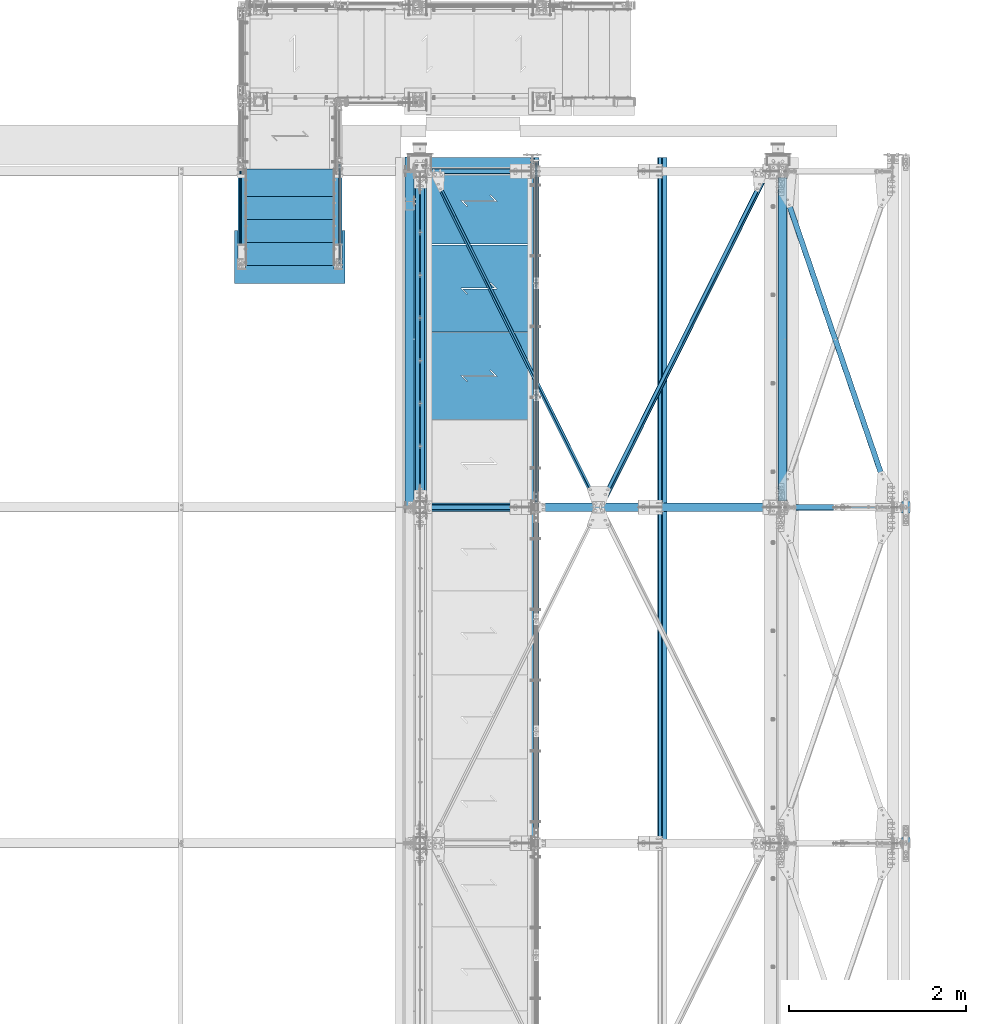
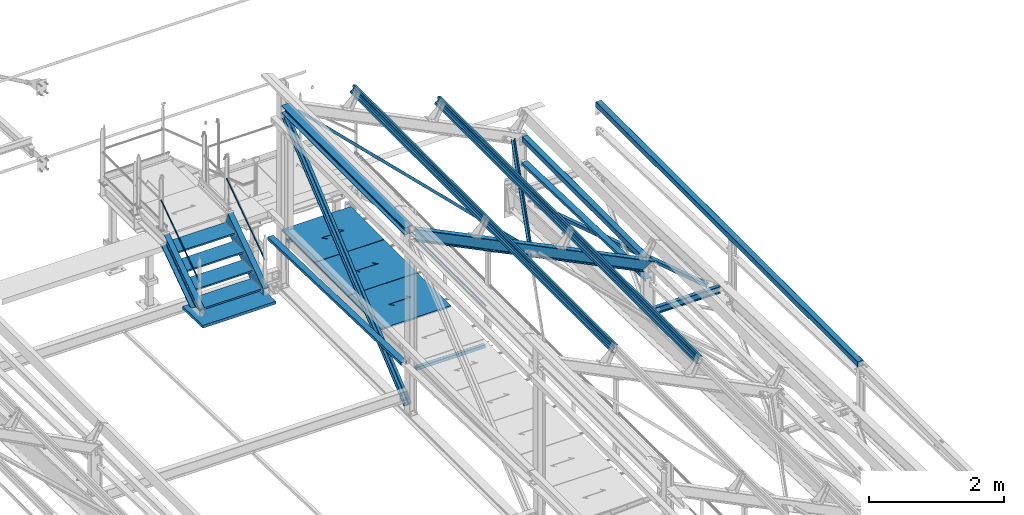
# One storey, part 57 of 496: 22 beams, 7 members, 29 elements without a shape of their own.
"""IFC2X3 building model written with IfcOpenShell, lengths in millimetres."""

from ifc_helpers import new_model, si_unit, frame, origin_with_axes, origin_2d_with_axis, place, context, subcontext, project, spatial, polyline, rectangle, hollow_rectangle, hollow_circle, i_section, l_section, u_section, outline, extrude, boolean, clip, halfspace, material, type_object, element, aggregate, save


model = new_model("IFC2X3")

# Units and contexts
model_context = context("Model", 3, precision=1e-05, world=origin_with_axes())
body_context = subcontext(model_context, "Body", "Model", "MODEL_VIEW")
ifc_project = project(units=[si_unit("LENGTHUNIT", "METRE", prefix="MILLI"), si_unit("AREAUNIT", "SQUARE_METRE"), si_unit("VOLUMEUNIT", "CUBIC_METRE"), si_unit("MASSUNIT", "GRAM", prefix="KILO"), si_unit("TIMEUNIT", "SECOND"), si_unit("PLANEANGLEUNIT", "RADIAN"), si_unit("SOLIDANGLEUNIT", "STERADIAN"), si_unit("THERMODYNAMICTEMPERATUREUNIT", "DEGREE_CELSIUS"), si_unit("LUMINOUSINTENSITYUNIT", "LUMEN")], contexts=[model_context])

# Site, building, storey
site_placement = place(None, origin_with_axes())
site = spatial("IfcSite", under=ifc_project, at=site_placement, CompositionType="ELEMENT")
building_placement = place(site_placement, origin_with_axes())
building = spatial("IfcBuilding", under=site, at=building_placement, Name="Undefined", CompositionType="ELEMENT")
storey_placement = place(building_placement, origin_with_axes())
storey = spatial("IfcBuildingStorey", under=building, at=storey_placement, Name="Undefined", CompositionType="ELEMENT", Elevation=0.0)

# Assembly, member
assembly_1_placement = place(storey_placement, origin_with_axes())
assembly_1 = element("IfcElementAssembly", 1, at=assembly_1_placement, inside=storey, Name="MAIN COURANTE", AssemblyPlace="NOTDEFINED", PredefinedType="NOTDEFINED")
ifc_material_1 = material(Name="Undefined/S235-E24")
member_type_1 = type_object("IfcMemberType", PredefinedType="NOTDEFINED")
member_1_placement = place(assembly_1_placement, frame((33369.9936634988, 14144.9998536997, 8651.13839395851), z_axis=(0.999999999999672, -6.66011674184119e-07, -4.61008081401814e-07), x_axis=(0.0, 0.822192191679776, 0.569209978778312)))
member_1 = element("IfcMember", 2, at=member_1_placement, type_object=member_type_1, material=ifc_material_1, Name="LISSE", context=body_context, shape_type="Clipping", body=[
    clip(clip(extrude(hollow_circle(Radius=10.64999962, WallThickness=2.0, at=origin_2d_with_axis()), frame((1395.35433691202, -1.13686837721616e-12, 7.38694435286663e-20), z_axis=(-1.0, 0.0, 0.0), x_axis=(0.0, -1.0, 0.0)), (0.0, 0.0, 1.0), 1404.17), halfspace(frame((1387.78549896895, 10.5802584847568, -0.00112410556903342), z_axis=(-0.822192191679508, 0.569209978778309, 6.66011673795452e-07), x_axis=(-0.569209978778123, -0.822192191679778, 4.61008086858783e-07)), True)), halfspace(frame((16.4615054726892, 14.9935154708171, -1.33328576339409e-05), z_axis=(0.822192191679509, -0.569209978778308, -6.66011673277761e-07), x_axis=(0.0, 0.0, -1.0)), True)),
])
aggregate(assembly_1, [member_1])

assembly_2_placement = place(storey_placement, origin_with_axes())
assembly_2 = element("IfcElementAssembly", 3, at=assembly_2_placement, inside=storey, Name="MAIN COURANTE", AssemblyPlace="NOTDEFINED", PredefinedType="NOTDEFINED")
member_2_placement = place(assembly_2_placement, frame((32249.9863365012, 14144.9998536997, 8651.13839395851), z_axis=(-0.999999999999672, -6.66011674184119e-07, -4.61008081401814e-07), x_axis=(0.0, 0.822192191679776, 0.569209978778312)))
member_2 = element("IfcMember", 4, at=member_2_placement, type_object=member_type_1, material=ifc_material_1, Name="LISSE", context=body_context, shape_type="Clipping", body=[
    clip(clip(extrude(hollow_circle(Radius=10.64999962, WallThickness=2.0, at=origin_2d_with_axis()), frame((1395.35433691202, -1.13686837721616e-12, 7.38694435286663e-20), z_axis=(-1.0, 0.0, 0.0), x_axis=(0.0, -1.0, 0.0)), (0.0, 0.0, 1.0), 1404.17), halfspace(frame((1387.78549896895, -10.5802584847571, -0.00112410556539544), z_axis=(-0.822192191679501, -0.569209978778319, 6.66011673795446e-07), x_axis=(0.0, 0.0, -1.0)), True)), halfspace(frame((16.4615054726892, -14.9935154708165, -1.33328503579833e-05), z_axis=(0.822192191679509, 0.569209978778308, -6.6601167379545e-07), x_axis=(-0.569209978778121, 0.822192191679779, 4.61008079582826e-07)), True)),
])
aggregate(assembly_2, [member_2])

# Assembly, beam
assembly_3_placement = place(storey_placement, origin_with_axes())
assembly_3 = element("IfcElementAssembly", 5, at=assembly_3_placement, inside=storey, AssemblyPlace="NOTDEFINED", PredefinedType="NOTDEFINED")
beam_type_1 = type_object("IfcBeamType", PredefinedType="NOTDEFINED")
beam_1_placement = place(assembly_3_placement, frame((36317.992690917, 11398.7879109724, 9504.82868291342), z_axis=(-0.784869556946141, 0.484835704476116, 0.38589392097352), x_axis=(0.435090896953333, 0.874605247906247, -0.213919544977068)))
beam_1 = element("IfcBeam", 6, at=beam_1_placement, type_object=beam_type_1, material=ifc_material_1, context=body_context, shape_type="Clipping", body=[
    clip(clip(extrude(l_section(Depth=50.0, Width=50.0, Thickness=5.0, FilletRadius=7.0, EdgeRadius=3.5, at=origin_2d_with_axis()), frame((4267.39151026902, 3.51953489934695e-12, -2.36887815489529e-13), z_axis=(-1.0, 0.0, 0.0), x_axis=(0.0, -1.0, 0.0)), (0.0, 0.0, 1.0), 4189.97), halfspace(frame((4208.92631276576, 24.998810484587, 25.0006239861068), z_axis=(-1.0, 0.0, 0.0), x_axis=(0.0, -1.0, 0.0)), True)), halfspace(frame((135.891296207992, 24.9993842734693, 24.9999999398824), z_axis=(-1.0, 0.0, 0.0), x_axis=(0.0, -1.0, 0.0)), False)),
])
aggregate(assembly_3, [beam_1])

assembly_4_placement = place(storey_placement, origin_with_axes())
assembly_4 = element("IfcElementAssembly", 7, at=assembly_4_placement, inside=storey, AssemblyPlace="NOTDEFINED", PredefinedType="NOTDEFINED")
beam_2_placement = place(assembly_4_placement, frame((34423.6781424162, 15198.7879095815, 10436.2000511246), z_axis=(0.78486954223706, 0.48483572817386, -0.385893921116557), x_axis=(0.435090922885268, -0.87460523476945, -0.213919545943613)))
beam_2 = element("IfcBeam", 8, at=beam_2_placement, type_object=beam_type_1, material=ifc_material_1, context=body_context, shape_type="Clipping", body=[
    clip(clip(extrude(l_section(Depth=50.0, Width=50.0, Thickness=5.0, FilletRadius=7.0, EdgeRadius=3.5, at=origin_2d_with_axis()), frame((4262.41802207915, -1.18305865717237e-13, 3.54917597151712e-13), z_axis=(-1.0, 0.0, 0.0), x_axis=(0.0, -1.0, 0.0)), (0.0, 0.0, 1.0), 4180.02), halfspace(frame((4208.92600506313, 24.999422256853, 25.0000000469408), z_axis=(-1.0, 0.0, 0.0), x_axis=(0.0, -1.0, 0.0)), True)), halfspace(frame((135.890867776812, 25.0000450435182, 25.0002856954561), z_axis=(1.0, 0.0, 0.0), x_axis=(0.0, 0.0, -1.0)), True)),
])
aggregate(assembly_4, [beam_2])

# Assembly, member
assembly_5_placement = place(storey_placement, origin_with_axes())
assembly_5 = element("IfcElementAssembly", 9, at=assembly_5_placement, inside=storey, AssemblyPlace="NOTDEFINED", PredefinedType="NOTDEFINED")
ifc_material_2 = material(Name="Undefined/S275-E28")
member_type_2 = type_object("IfcMemberType", Name="UPN260", PredefinedType="NOTDEFINED")
member_3_placement = place(assembly_5_placement, frame((33354.9957050653, 15220.1081967775, 8803.11488296132), z_axis=(-2.38199999876088e-06, 0.569209978780056, -0.822192191675118), x_axis=(-8.09999997507615e-07, -0.822192191679509, -0.569209978778121)))
member_3 = element("IfcMember", 10, at=member_3_placement, type_object=member_type_2, material=ifc_material_2, ObjectType="UPN260", context=body_context, shape_type="Clipping", body=[
    clip(clip(clip(extrude(u_section(Depth=260.0, FlangeWidth=90.0, WebThickness=10.0, FlangeThickness=14.0, FilletRadius=14.0, EdgeRadius=7.0, FlangeSlope=0.0798299857122373, at=origin_2d_with_axis()), frame((1532.05974941516, 3.24426271229202e-19, 1.50656932765752e-12), z_axis=(-1.0, 0.0, 0.0), x_axis=(0.0, -1.0, 0.0)), (0.0, 0.0, 1.0), 1652.65), halfspace(frame((1475.10561376755, -44.9999999999982, -130.0), z_axis=(0.594754891759256, -2.93590080272386e-06, 0.803907095826263), x_axis=(-0.803907095829728, -3.97667463540568e-10, 0.594754891761819)), False)), halfspace(frame((1280.85769771495, 106.407624448384, -129.999853684547), z_axis=(-0.822192191678566, 5.58458236969981e-08, 0.569209978780058), x_axis=(0.569209978777471, -2.93579533354204e-06, 0.822192191675117)), True)), halfspace(frame((81.2187427422505, 545.001446996483, 130.001191003446), z_axis=(0.954513538741863, -9.28664575673263e-07, -0.298167577643218), x_axis=(1.71699999918928e-06, 0.999999999995689, 2.38199999876088e-06)), True)),
])
aggregate(assembly_5, [member_3])

assembly_6_placement = place(storey_placement, origin_with_axes())
assembly_6 = element("IfcElementAssembly", 11, at=assembly_6_placement, inside=storey, AssemblyPlace="NOTDEFINED", PredefinedType="NOTDEFINED")
member_4_placement = place(assembly_6_placement, frame((32265.0064946267, 14166.9970857892, 8074.0379599759), z_axis=(2.38199999876088e-06, 0.569209978780056, -0.822192191675118), x_axis=(-1.7169999996433e-06, 0.822192191678566, 0.56920997877747)))
member_4 = element("IfcMember", 12, at=member_4_placement, type_object=member_type_2, material=ifc_material_2, ObjectType="UPN260", context=body_context, shape_type="Clipping", body=[
    clip(clip(clip(extrude(u_section(Depth=260.0, FlangeWidth=90.0, WebThickness=10.0, FlangeThickness=14.0, FilletRadius=14.0, EdgeRadius=7.0, FlangeSlope=0.0798299857122373, at=origin_2d_with_axis()), frame((1401.450854294, -1.81898940354586e-12, 2.27373675443232e-13), z_axis=(-1.0, 0.0, 0.0), x_axis=(0.0, -1.0, 0.0)), (0.0, 0.0, 1.0), 1652.65), halfspace(frame((-194.248465676397, 44.9999999999982, -130.0), z_axis=(-0.594754891759256, -2.93590079459986e-06, 0.803907095826263), x_axis=(0.803907095829729, -3.97667463540568e-10, 0.594754891761818)), False)), halfspace(frame((1199.63884956697, 544.98906444852, 130.001190898261), z_axis=(-0.954513538741863, -9.28664579145766e-07, -0.298167577643217), x_axis=(1.71700000282726e-06, -0.999999999995689, -2.38199999876088e-06)), True)), halfspace(frame((-0.000105426983282086, 106.407623989038, -129.999853760241), z_axis=(0.822192191678561, 5.58458236969708e-08, 0.569209978780065), x_axis=(1.71700000282726e-06, -0.999999999995689, -2.38199999876088e-06)), True)),
])
aggregate(assembly_6, [member_4])

# Assembly, beam
assembly_7_placement = place(storey_placement, origin_with_axes())
assembly_7 = element("IfcElementAssembly", 13, at=assembly_7_placement, inside=storey, Name="Steel Assembly", AssemblyPlace="NOTDEFINED", PredefinedType="NOTDEFINED")
ifc_material_3 = material(Name="POLYURETHANE")
beam_type_2 = type_object("IfcBeamType", PredefinedType="NOTDEFINED")
beam_3_placement = place(assembly_7_placement, frame((32809.9947340707, 14532.1706378134, 7968.49328384745), z_axis=(-1.0, 0.0, 0.0), x_axis=(0.0, -0.999506556345276, 0.031410887010852)))
beam_3 = element("IfcBeam", 14, at=beam_3_placement, type_object=beam_type_2, material=ifc_material_3, context=body_context, shape_type="SweptSolid", body=[
    extrude(rectangle(XDim=50.0, YDim=1250.0, at=origin_2d_with_axis()), frame((600.000000000075, -4.16333634234486e-15, 0.0), z_axis=(-1.0, 0.0, 0.0), x_axis=(0.0, -1.0, 0.0)), (0.0, 0.0, 1.0), 600.0),
])
aggregate(assembly_7, [beam_3])

assembly_8_placement = place(storey_placement, origin_with_axes())
assembly_8 = element("IfcElementAssembly", 15, at=assembly_8_placement, inside=storey, Name="MARCHE", AssemblyPlace="NOTDEFINED", PredefinedType="NOTDEFINED")
beam_type_3 = type_object("IfcBeamType", PredefinedType="NOTDEFINED")
beam_4_placement = place(assembly_8_placement, frame((32809.9938089558, 14444.9997910501, 8145.0000000973), z_axis=(-1.0, 0.0, 0.0), x_axis=(0.0, -1.0, 0.0)))
beam_4 = element("IfcBeam", 16, at=beam_4_placement, type_object=beam_type_3, material=ifc_material_1, Name="MARCHE", context=body_context, shape_type="SweptSolid", body=[
    extrude(rectangle(XDim=30.0, YDim=994.0, at=origin_2d_with_axis()), frame((310.0, 0.0, 0.0), z_axis=(-1.0, 0.0, 0.0), x_axis=(0.0, -1.0, 0.0)), (0.0, 0.0, 1.0), 310.0),
])
aggregate(assembly_8, [beam_4])

assembly_9_placement = place(storey_placement, origin_with_axes())
assembly_9 = element("IfcElementAssembly", 17, at=assembly_9_placement, inside=storey, Name="MARCHE", AssemblyPlace="NOTDEFINED", PredefinedType="NOTDEFINED")
beam_5_placement = place(assembly_9_placement, frame((32809.9938089558, 14704.9997910501, 8325.00000007297), z_axis=(-1.0, 0.0, 0.0), x_axis=(0.0, -1.0, 0.0)))
beam_5 = element("IfcBeam", 18, at=beam_5_placement, type_object=beam_type_3, material=ifc_material_1, Name="MARCHE", context=body_context, shape_type="SweptSolid", body=[
    extrude(rectangle(XDim=30.0, YDim=994.0, at=origin_2d_with_axis()), frame((310.0, 0.0, 0.0), z_axis=(-1.0, 0.0, 0.0), x_axis=(0.0, -1.0, 0.0)), (0.0, 0.0, 1.0), 310.0),
])
aggregate(assembly_9, [beam_5])

assembly_10_placement = place(storey_placement, origin_with_axes())
assembly_10 = element("IfcElementAssembly", 19, at=assembly_10_placement, inside=storey, Name="MARCHE", AssemblyPlace="NOTDEFINED", PredefinedType="NOTDEFINED")
beam_6_placement = place(assembly_10_placement, frame((32809.9938089558, 14964.9997910501, 8505.00000004865), z_axis=(-1.0, 0.0, 0.0), x_axis=(0.0, -1.0, 0.0)))
beam_6 = element("IfcBeam", 20, at=beam_6_placement, type_object=beam_type_3, material=ifc_material_1, Name="MARCHE", context=body_context, shape_type="SweptSolid", body=[
    extrude(rectangle(XDim=30.0, YDim=994.0, at=origin_2d_with_axis()), frame((310.0, 0.0, 0.0), z_axis=(-1.0, 0.0, 0.0), x_axis=(0.0, -1.0, 0.0)), (0.0, 0.0, 1.0), 310.0),
])
aggregate(assembly_10, [beam_6])

assembly_11_placement = place(storey_placement, origin_with_axes())
assembly_11 = element("IfcElementAssembly", 21, at=assembly_11_placement, inside=storey, Name="MARCHE", AssemblyPlace="NOTDEFINED", PredefinedType="NOTDEFINED")
beam_7_placement = place(assembly_11_placement, frame((32809.9938089558, 15224.9997910501, 8685.0), z_axis=(-1.0, 0.0, 0.0), x_axis=(0.0, -1.0, 0.0)))
beam_7 = element("IfcBeam", 22, at=beam_7_placement, type_object=beam_type_3, material=ifc_material_1, Name="MARCHE", context=body_context, shape_type="SweptSolid", body=[
    extrude(rectangle(XDim=30.0, YDim=994.0, at=origin_2d_with_axis()), frame((310.0, 0.0, 0.0), z_axis=(-1.0, 0.0, 0.0), x_axis=(0.0, -1.0, 0.0)), (0.0, 0.0, 1.0), 310.0),
])
aggregate(assembly_11, [beam_7])

assembly_12_placement = place(storey_placement, origin_with_axes())
assembly_12 = element("IfcElementAssembly", 23, at=assembly_12_placement, inside=storey, AssemblyPlace="NOTDEFINED", PredefinedType="NOTDEFINED")
beam_type_4 = type_object("IfcBeamType", PredefinedType="NOTDEFINED")
beam_8_placement = place(assembly_12_placement, frame((39627.1613878752, 11396.013468131, 7535.78531913164), z_axis=(0.946212867827137, 0.323385100940919, -0.0101629349981538), x_axis=(-0.323544727855661, 0.945746015578088, -0.0297200789867413)))
beam_8 = element("IfcBeam", 24, at=beam_8_placement, type_object=beam_type_4, material=ifc_material_1, context=body_context, shape_type="Clipping", body=[
    clip(clip(extrude(l_section(Depth=60.0, Width=60.0, Thickness=6.0, FilletRadius=8.0, EdgeRadius=4.0, at=origin_2d_with_axis()), frame((3750.95250364947, 9.09494701772928e-13, -6.36452768548759e-14), z_axis=(-1.0, 0.0, 0.0), x_axis=(0.0, -1.0, 0.0)), (0.0, 0.0, 1.0), 3483.91), halfspace(frame((3710.26424680169, 59.9981500481172, -29.9999902700147), z_axis=(-0.999999999999296, 1.18625956791219e-06, 6.35888351226559e-12), x_axis=(1.69800000215235e-06, 0.999999999998558, 0.0)), True)), halfspace(frame((307.727647946698, 60.0021863114052, 29.9999854501075), z_axis=(0.999999999999672, -6.66011674184119e-07, -4.61008081401814e-07), x_axis=(1.69800000215235e-06, 0.999999999998558, 0.0)), True)),
])
aggregate(assembly_12, [beam_8])

assembly_13_placement = place(storey_placement, origin_with_axes())
assembly_13 = element("IfcElementAssembly", 25, at=assembly_13_placement, inside=storey, Name="LISSE", AssemblyPlace="NOTDEFINED", PredefinedType="NOTDEFINED")
beam_type_5 = type_object("IfcBeamType", PredefinedType="NOTDEFINED")
beam_9_placement = place(assembly_13_placement, frame((34163.5001162926, 11402.9585391484, 8171.89575101457), z_axis=(1.0, 0.0, 0.0), x_axis=(0.0, 0.999506445341009, -0.0314144190107172)))
beam_9 = element("IfcBeam", 26, at=beam_9_placement, type_object=beam_type_5, material=ifc_material_1, Name="LISSE", context=body_context, shape_type="Clipping", body=[
    clip(extrude(u_section(Depth=100.0, FlangeWidth=50.0, WebThickness=4.0, FlangeThickness=4.0, at=origin_2d_with_axis()), frame((3989.01014791664, 0.0, 0.0), z_axis=(-1.0, 0.0, 0.0), x_axis=(0.0, -1.0, 0.0)), (0.0, 0.0, 1.0), 3989.01), halfspace(frame((3959.78106204689, -24.99999999994, -50.0), z_axis=(0.999506472307554, 0.0314135610096964, 0.0), x_axis=(0.0, 0.0, 1.0)), False)),
])
aggregate(assembly_13, [beam_9])

assembly_14_placement = place(storey_placement, origin_with_axes())
assembly_14 = element("IfcElementAssembly", 27, at=assembly_14_placement, inside=storey, Name="LISSE", AssemblyPlace="NOTDEFINED", PredefinedType="NOTDEFINED")
beam_10_placement = place(assembly_14_placement, frame((38380.0000000142, 11400.0, 8171.98873515491), z_axis=(1.0, 0.0, 0.0), x_axis=(0.0, 0.999506445341009, -0.0314144190107172)))
beam_10 = element("IfcBeam", 28, at=beam_10_placement, type_object=beam_type_5, material=ifc_material_1, Name="LISSE", context=body_context, shape_type="Clipping", body=[
    clip(clip(extrude(u_section(Depth=100.0, FlangeWidth=50.0, WebThickness=4.0, FlangeThickness=4.0, at=origin_2d_with_axis()), frame((3738.43140425554, 0.0, 0.0), z_axis=(-1.0, 0.0, 0.0), x_axis=(0.0, -1.0, 0.0)), (0.0, 0.0, 1.0), 3674.99), halfspace(frame((3734.02168286743, 89.8070816101499, 49.9999999858046), z_axis=(-0.999506472307554, -0.0314135610096736, 0.0), x_axis=(0.0, 0.0, 1.0)), True)), halfspace(frame((63.1144992302961, 61.0134432793748, 49.9999999858046), z_axis=(-0.999506472307554, -0.0314135610096736, 0.0), x_axis=(0.0, 0.0, 1.0)), False)),
])
aggregate(assembly_14, [beam_10])

assembly_15_placement = place(storey_placement, origin_with_axes())
assembly_15 = element("IfcElementAssembly", 29, at=assembly_15_placement, inside=storey, Name="LISSE", AssemblyPlace="NOTDEFINED", PredefinedType="NOTDEFINED")
beam_type_6 = type_object("IfcBeamType", PredefinedType="NOTDEFINED")
beam_11_placement = place(assembly_15_placement, frame((39775.0, 7605.0, 8500.0), z_axis=(0.0, 0.0, 1.0), x_axis=(0.0, 1.0, 0.0)))
beam_11 = element("IfcBeam", 30, at=beam_11_placement, type_object=beam_type_6, material=ifc_material_1, Name="LISSE", context=body_context, shape_type="SweptSolid", body=[
    extrude(hollow_rectangle(XDim=100.0, YDim=100.0, WallThickness=4.0, InnerFilletRadius=4.0, OuterFilletRadius=8.0, at=origin_2d_with_axis()), frame((7755.0, 0.0, 0.0), z_axis=(-1.0, 0.0, 0.0), x_axis=(0.0, -1.0, 0.0)), (0.0, 0.0, 1.0), 7755.0),
])
aggregate(assembly_15, [beam_11])

assembly_16_placement = place(storey_placement, origin_with_axes())
assembly_16 = element("IfcElementAssembly", 31, at=assembly_16_placement, inside=storey, Name="LISSE", AssemblyPlace="NOTDEFINED", PredefinedType="NOTDEFINED")
beam_12_placement = place(assembly_16_placement, frame((38380.0, 11470.0, 8500.0), z_axis=(0.0, 0.0, 1.0), x_axis=(0.0, 1.0, 0.0)))
beam_12 = element("IfcBeam", 32, at=beam_12_placement, type_object=beam_type_6, material=ifc_material_1, Name="LISSE", context=body_context, shape_type="SweptSolid", body=[
    extrude(hollow_rectangle(XDim=100.0, YDim=100.0, WallThickness=4.0, InnerFilletRadius=4.0, OuterFilletRadius=8.0, at=origin_2d_with_axis()), frame((3660.0, 0.0, 0.0), z_axis=(-1.0, 0.0, 0.0), x_axis=(0.0, -1.0, 0.0)), (0.0, 0.0, 1.0), 3660.0),
])
aggregate(assembly_16, [beam_12])

assembly_17_placement = place(storey_placement, origin_with_axes())
assembly_17 = element("IfcElementAssembly", 33, at=assembly_17_placement, inside=storey, AssemblyPlace="NOTDEFINED", PredefinedType="NOTDEFINED")
beam_type_7 = type_object("IfcBeamType", PredefinedType="NOTDEFINED")
beam_13_placement = place(assembly_17_placement, frame((35536.4915949059, 15355.0003049488, 8115.0), z_axis=(0.0, 0.0, 1.0), x_axis=(-1.0, 0.0, 0.0)))
beam_13 = element("IfcBeam", 34, at=beam_13_placement, type_object=beam_type_7, material=ifc_material_1, context=body_context, shape_type="CSG", body=[
    boolean("DIFFERENCE", extrude(outline(polyline([(0.0, 0.0), (1179.99169921875, 0.0), (1179.99169921875, 980.0), (-9.39995516091585e-07, 980.0), (0.0, 0.0)])), frame((0.0, 0.0, -15.0), z_axis=(0.0, 0.0, 1.0), x_axis=(1.0, 0.0, 0.0)), (0.0, 0.0, 1.0), 30.0), extrude(outline(polyline([(0.0, 0.0), (9.99999999997453, 6.91215973347425e-11), (10.0000000004329, 75.8578643791443), (282.842712400121, -196.984848017997), (282.842712400743, -96.9848480190813), (272.842712400776, -96.9848480191613), (272.842712400299, -172.842712398218), (0.0, 100.0), (0.0, 0.0)])), frame((724.286946489367, 555.710676888644, -17.5), z_axis=(0.0, 0.0, 1.0), x_axis=(-0.707106781186457, -0.707106781186639, 0.0)), (0.0, 0.0, 1.0), 35.0)),
])
aggregate(assembly_17, [beam_13])

assembly_18_placement = place(storey_placement, origin_with_axes())
assembly_18 = element("IfcElementAssembly", 35, at=assembly_18_placement, inside=storey, AssemblyPlace="NOTDEFINED", PredefinedType="NOTDEFINED")
beam_14_placement = place(assembly_18_placement, frame((35536.4915949059, 14365.0003097181, 8115.0), z_axis=(0.0, 0.0, 1.0), x_axis=(-1.0, 0.0, 0.0)))
beam_14 = element("IfcBeam", 36, at=beam_14_placement, type_object=beam_type_7, material=ifc_material_1, context=body_context, shape_type="CSG", body=[
    boolean("DIFFERENCE", extrude(outline(polyline([(0.0, 0.0), (1179.99169921875, 0.0), (1179.99169921875, 980.0), (-9.39995516091585e-07, 980.0), (0.0, 0.0)])), frame((0.0, 0.0, -15.0), z_axis=(0.0, 0.0, 1.0), x_axis=(1.0, 0.0, 0.0)), (0.0, 0.0, 1.0), 30.0), extrude(outline(polyline([(0.0, 0.0), (9.99999999997453, 6.91215973347425e-11), (10.0000000004329, 75.8578643791443), (282.842712400121, -196.984848017997), (282.842712400743, -96.9848480190813), (272.842712400776, -96.9848480191613), (272.842712400299, -172.842712398218), (0.0, 100.0), (0.0, 0.0)])), frame((724.286946489367, 555.710676888644, -17.5), z_axis=(0.0, 0.0, 1.0), x_axis=(-0.707106781186457, -0.707106781186639, 0.0)), (0.0, 0.0, 1.0), 35.0)),
])
aggregate(assembly_18, [beam_14])

assembly_19_placement = place(storey_placement, origin_with_axes())
assembly_19 = element("IfcElementAssembly", 37, at=assembly_19_placement, inside=storey, AssemblyPlace="NOTDEFINED", PredefinedType="NOTDEFINED")
beam_15_placement = place(assembly_19_placement, frame((35536.4915949059, 13375.0003144873, 8115.0), z_axis=(0.0, 0.0, 1.0), x_axis=(-1.0, 0.0, 0.0)))
beam_15 = element("IfcBeam", 38, at=beam_15_placement, type_object=beam_type_7, material=ifc_material_1, context=body_context, shape_type="CSG", body=[
    boolean("DIFFERENCE", extrude(outline(polyline([(0.0, 0.0), (1179.99169921875, 0.0), (1179.99169921875, 980.0), (-9.39995516091585e-07, 980.0), (0.0, 0.0)])), frame((0.0, 0.0, -15.0), z_axis=(0.0, 0.0, 1.0), x_axis=(1.0, 0.0, 0.0)), (0.0, 0.0, 1.0), 30.0), extrude(outline(polyline([(0.0, 0.0), (9.99999999997453, 6.91215973347425e-11), (10.0000000004329, 75.8578643791443), (282.842712400121, -196.984848017997), (282.842712400743, -96.9848480190813), (272.842712400776, -96.9848480191613), (272.842712400299, -172.842712398218), (0.0, 100.0), (0.0, 0.0)])), frame((724.286946489367, 555.710676888644, -17.5), z_axis=(0.0, 0.0, 1.0), x_axis=(-0.707106781186457, -0.707106781186639, 0.0)), (0.0, 0.0, 1.0), 35.0)),
])
aggregate(assembly_19, [beam_15])

assembly_20_placement = place(storey_placement, origin_with_axes())
assembly_20 = element("IfcElementAssembly", 39, at=assembly_20_placement, inside=storey, Name="MAIN COURANTE", AssemblyPlace="NOTDEFINED", PredefinedType="NOTDEFINED")
beam_type_8 = type_object("IfcBeamType", PredefinedType="NOTDEFINED")
beam_16_placement = place(assembly_20_placement, frame((35593.9917225569, 15300.0034325386, 8673.79999660984), z_axis=(0.0, 0.0, 1.0), x_axis=(0.0, -1.0, 0.0)))
beam_16 = element("IfcBeam", 40, at=beam_16_placement, type_object=beam_type_8, material=ifc_material_1, Name="LISSE", context=body_context, shape_type="SweptSolid", body=[
    extrude(hollow_circle(Radius=13.44999981, WallThickness=2.0, at=origin_2d_with_axis()), frame((3845.0034383235, -7.91283071904719e-22, 7.95128074845232e-22), z_axis=(-1.0, 0.0, 0.0), x_axis=(0.0, -1.0, 0.0)), (0.0, 0.0, 1.0), 3845.0),
])
aggregate(assembly_20, [beam_16])

assembly_21_placement = place(storey_placement, origin_with_axes())
assembly_21 = element("IfcElementAssembly", 41, at=assembly_21_placement, inside=storey, AssemblyPlace="NOTDEFINED", PredefinedType="NOTDEFINED")
beam_type_9 = type_object("IfcBeamType", Name="HEA140", PredefinedType="NOTDEFINED")
beam_17_placement = place(assembly_21_placement, frame((34283.5, 15125.0, 10489.5), z_axis=(0.0, 0.0, 1.0), x_axis=(0.0, -1.0, 0.0)))
beam_17 = element("IfcBeam", 42, at=beam_17_placement, type_object=beam_type_9, material=ifc_material_2, ObjectType="HEA140", context=body_context, shape_type="SweptSolid", body=[
    extrude(i_section(OverallWidth=140.0, OverallDepth=133.0, WebThickness=5.5, FlangeThickness=8.5, FilletRadius=12.0, at=origin_2d_with_axis()), frame((3650.0, 0.0, 0.0), z_axis=(-1.0, 0.0, 0.0), x_axis=(0.0, -1.0, 0.0)), (0.0, 0.0, 1.0), 3650.0),
])
aggregate(assembly_21, [beam_17])

assembly_22_placement = place(storey_placement, origin_with_axes())
assembly_22 = element("IfcElementAssembly", 43, at=assembly_22_placement, inside=storey, Name="SHED", AssemblyPlace="NOTDEFINED", PredefinedType="NOTDEFINED")
beam_type_10 = type_object("IfcBeamType", PredefinedType="NOTDEFINED")
beam_18_placement = place(assembly_22_placement, frame((37020.1555043103, 7605.00007961586, 9532.89989901077), z_axis=(0.441221071222121, 0.0, 0.897398443451739), x_axis=(0.0, 1.0, 0.0)))
beam_18 = element("IfcBeam", 44, at=beam_18_placement, type_object=beam_type_10, material=ifc_material_1, Name="SHED", context=body_context, shape_type="SweptSolid", body=[
    extrude(outline(polyline([(-27.9999999860338, 36.0000000101354), (-27.999999986052, 70.0000000101354), (28.0000000138389, 70.0000000101209), (28.0000000138425, 58.0000000101209), (26.5000000138534, 58.0000000101209), (26.5000000138352, 68.5000000101172), (-26.4999999860593, 68.5000000101354), (-26.4999999860338, 36.7000007730749), (-1.49999998607018, 15.6999998194005), (-1.49999998605563, -15.6999997991297), (-26.4999999859974, -36.7000007527895), (-26.4999999859829, -68.49999998985), (26.5000000139153, -68.4999999898646), (26.500000013908, -57.9999999898646), (28.0000000139116, -57.9999999898646), (28.0000000139153, -69.9999999898646), (-27.9999999859756, -69.99999998985), (-27.9999999859901, -35.99999998985), (-2.99999998605927, -14.9999999898646), (-2.9999999860629, 15.0000000101354), (-27.9999999860338, 36.0000000101354)])), frame((7750.00000000006, -3.63797880548905e-12, 0.0), z_axis=(-1.0, 0.0, 0.0), x_axis=(0.0, -1.0, 0.0)), (0.0, 0.0, 1.0), 7750.0),
])
aggregate(assembly_22, [beam_18])

assembly_23_placement = place(storey_placement, origin_with_axes())
assembly_23 = element("IfcElementAssembly", 45, at=assembly_23_placement, inside=storey, Name="SHED", AssemblyPlace="NOTDEFINED", PredefinedType="NOTDEFINED")
beam_19_placement = place(assembly_23_placement, frame((35571.3221700708, 7605.00007961586, 10245.2429546827), z_axis=(0.441221071222121, 0.0, 0.897398443451739), x_axis=(0.0, 1.0, 0.0)))
beam_19 = element("IfcBeam", 46, at=beam_19_placement, type_object=beam_type_10, material=ifc_material_1, Name="SHED", context=body_context, shape_type="SweptSolid", body=[
    extrude(outline(polyline([(-27.9999999860338, 36.0000000101354), (-27.999999986052, 70.0000000101354), (28.0000000138389, 70.0000000101209), (28.0000000138425, 58.0000000101209), (26.5000000138534, 58.0000000101209), (26.5000000138352, 68.5000000101172), (-26.4999999860593, 68.5000000101354), (-26.4999999860338, 36.7000007730749), (-1.49999998607018, 15.6999998194005), (-1.49999998605563, -15.6999997991297), (-26.4999999859974, -36.7000007527895), (-26.4999999859829, -68.49999998985), (26.5000000139153, -68.4999999898646), (26.500000013908, -57.9999999898646), (28.0000000139116, -57.9999999898646), (28.0000000139153, -69.9999999898646), (-27.9999999859756, -69.99999998985), (-27.9999999859901, -35.99999998985), (-2.99999998605927, -14.9999999898646), (-2.9999999860629, 15.0000000101354), (-27.9999999860338, 36.0000000101354)])), frame((7750.00000000006, -3.63797880548905e-12, 0.0), z_axis=(-1.0, 0.0, 0.0), x_axis=(0.0, -1.0, 0.0)), (0.0, 0.0, 1.0), 7750.0),
])
aggregate(assembly_23, [beam_19])

# Assembly, member
assembly_24_placement = place(storey_placement, origin_with_axes())
assembly_24 = element("IfcElementAssembly", 47, at=assembly_24_placement, inside=storey, AssemblyPlace="NOTDEFINED", PredefinedType="NOTDEFINED")
member_type_3 = type_object("IfcMemberType", Name="UPN80", PredefinedType="NOTDEFINED")
member_5_placement = place(assembly_24_placement, frame((34307.5000000297, 11400.0000000125, 7249.99999999999), z_axis=(0.0, -0.64093909508163, 0.76759173809776), x_axis=(0.0, 0.767591736292195, 0.640939097243985)))
member_5 = element("IfcMember", 48, at=member_5_placement, type_object=member_type_3, material=ifc_material_2, ObjectType="UPN80", context=body_context, shape_type="Clipping", body=[
    clip(clip(extrude(u_section(Depth=80.0, FlangeWidth=45.0, WebThickness=6.0, FlangeThickness=8.0, FilletRadius=8.0, EdgeRadius=4.0, FlangeSlope=0.0798299857122373, at=origin_2d_with_axis()), frame((4910.05224962439, 0.0, 1.04649042213807e-12), z_axis=(-1.0, 0.0, 0.0), x_axis=(0.0, -1.0, 0.0)), (0.0, 0.0, 1.0), 4869.56), halfspace(frame((4830.5483535527, 27.5000000297296, 39.9999985196043), z_axis=(1.0, 0.0, 0.0), x_axis=(0.0, 1.0, 0.0)), False)), halfspace(frame((119.999999989826, 27.5000000297296, 39.9999985196016), z_axis=(1.0, 0.0, 0.0), x_axis=(0.0, 1.0, 0.0)), True)),
])
aggregate(assembly_24, [member_5])

assembly_25_placement = place(storey_placement, origin_with_axes())
assembly_25 = element("IfcElementAssembly", 49, at=assembly_25_placement, inside=storey, AssemblyPlace="NOTDEFINED", PredefinedType="NOTDEFINED")
member_6_placement = place(assembly_25_placement, frame((34252.5000000316, 15200.0000003585, 10422.9999997217), z_axis=(0.0, -0.64093909508163, 0.76759173809776), x_axis=(0.0, -0.76759173809776, -0.64093909508163)))
member_6 = element("IfcMember", 50, at=member_6_placement, type_object=member_type_3, material=ifc_material_2, ObjectType="UPN80", context=body_context, shape_type="Clipping", body=[
    clip(clip(extrude(u_section(Depth=80.0, FlangeWidth=45.0, WebThickness=6.0, FlangeThickness=8.0, FilletRadius=8.0, EdgeRadius=4.0, FlangeSlope=0.0798299857122373, at=origin_2d_with_axis()), frame((4910.05224962439, 0.0, 1.04649042213807e-12), z_axis=(-1.0, 0.0, 0.0), x_axis=(0.0, -1.0, 0.0)), (0.0, 0.0, 1.0), 4869.56), halfspace(frame((4830.5483535527, 27.5000000297296, 39.9999985196043), z_axis=(-1.0, 0.0, 0.0), x_axis=(0.0, -1.0, 0.0)), True)), halfspace(frame((119.999999989826, 27.5000000297296, 39.9999985196016), z_axis=(-1.0, 0.0, 0.0), x_axis=(0.0, -1.0, 0.0)), False)),
])
aggregate(assembly_25, [member_6])

# Assembly, beam
assembly_26_placement = place(storey_placement, origin_with_axes())
assembly_26 = element("IfcElementAssembly", 51, at=assembly_26_placement, inside=storey, AssemblyPlace="NOTDEFINED", PredefinedType="NOTDEFINED")
beam_type_11 = type_object("IfcBeamType", PredefinedType="NOTDEFINED")
beam_20_placement = place(assembly_26_placement, frame((34357.991943003, 15200.0, 8015.0), z_axis=(0.0, -1.0, 0.0), x_axis=(1.0, 0.0, 0.0)))
beam_20 = element("IfcBeam", 52, at=beam_20_placement, type_object=beam_type_11, material=ifc_material_1, context=body_context, shape_type="SweptSolid", body=[
    extrude(hollow_rectangle(XDim=60.0, YDim=60.0, WallThickness=3.0, InnerFilletRadius=3.0, OuterFilletRadius=6.0, at=origin_2d_with_axis()), frame((1181.99977105896, 0.0, 0.0), z_axis=(-1.0, 0.0, 0.0), x_axis=(0.0, -1.0, 0.0)), (0.0, 0.0, 1.0), 1182.0),
])
aggregate(assembly_26, [beam_20])

assembly_27_placement = place(storey_placement, origin_with_axes())
assembly_27 = element("IfcElementAssembly", 53, at=assembly_27_placement, inside=storey, AssemblyPlace="NOTDEFINED", PredefinedType="NOTDEFINED")
beam_21_placement = place(assembly_27_placement, frame((34357.991943003, 11400.0, 8015.0), z_axis=(0.0, -1.0, 0.0), x_axis=(1.0, 0.0, 0.0)))
beam_21 = element("IfcBeam", 54, at=beam_21_placement, type_object=beam_type_11, material=ifc_material_1, context=body_context, shape_type="SweptSolid", body=[
    extrude(hollow_rectangle(XDim=60.0, YDim=60.0, WallThickness=3.0, InnerFilletRadius=3.0, OuterFilletRadius=6.0, at=origin_2d_with_axis()), frame((1181.99977105896, 0.0, 0.0), z_axis=(-1.0, 0.0, 0.0), x_axis=(0.0, -1.0, 0.0)), (0.0, 0.0, 1.0), 1182.0),
])
aggregate(assembly_27, [beam_21])

assembly_28_placement = place(storey_placement, origin_with_axes())
assembly_28 = element("IfcElementAssembly", 55, at=assembly_28_placement, inside=storey, AssemblyPlace="NOTDEFINED", PredefinedType="NOTDEFINED")
beam_type_12 = type_object("IfcBeamType", Name="IPE120", PredefinedType="NOTDEFINED")
beam_22_placement = place(assembly_28_placement, frame((38430.0, 11399.9999999999, 7631.71089231417), z_axis=(0.0, 0.031410887010906, 0.999506556345274), x_axis=(1.0, 0.0, 0.0)))
beam_22 = element("IfcBeam", 56, at=beam_22_placement, type_object=beam_type_12, material=ifc_material_2, ObjectType="IPE120", context=body_context, shape_type="SweptSolid", body=[
    extrude(i_section(OverallWidth=64.0, OverallDepth=120.0, WebThickness=4.400000095, FlangeThickness=6.300000191, FilletRadius=7.0, at=origin_2d_with_axis()), frame((1125.00000000002, 0.0, 0.0), z_axis=(-1.0, 0.0, 0.0), x_axis=(0.0, -1.0, 0.0)), (0.0, 0.0, 1.0), 1125.0),
])
aggregate(assembly_28, [beam_22])

# Assembly, member
assembly_29_placement = place(storey_placement, origin_with_axes())
assembly_29 = element("IfcElementAssembly", 57, at=assembly_29_placement, inside=storey, Name="TRAVERSE SHED", AssemblyPlace="NOTDEFINED", PredefinedType="NOTDEFINED")
member_type_4 = type_object("IfcMemberType", Name="IPE200", PredefinedType="NOTDEFINED")
member_7_placement = place(assembly_29_placement, frame((34305.8779065378, 11399.9999999968, 10466.2601489394), z_axis=(0.441221071222121, 0.0, 0.897398443451739), x_axis=(0.897398510539058, 0.0, -0.441220934773362)))
member_7 = element("IfcMember", 58, at=member_7_placement, type_object=member_type_4, material=ifc_material_2, Name="TRAVERSE SHED", ObjectType="IPE200", context=body_context, shape_type="Clipping", body=[
    clip(clip(extrude(i_section(OverallWidth=100.0, OverallDepth=200.0, WebThickness=5.599999905, FlangeThickness=8.5, FilletRadius=12.0, at=origin_2d_with_axis()), frame((4652.25219148987, 0.0, 0.0), z_axis=(-1.0, 0.0, 0.0), x_axis=(0.0, -1.0, 0.0)), (0.0, 0.0, 1.0), 4763.89), halfspace(frame((4421.9420250161, -11399.9999999968, -100.0), z_axis=(0.848887783899296, 0.0, -0.528573107854099), x_axis=(0.0, -1.0, 0.0)), False)), halfspace(frame((5.83309030194869, 3.19837843542485e-09, 102.867936075316), z_axis=(-0.89739851053906, 0.0, -0.44122093477336), x_axis=(0.0, -1.0, 0.0)), False)),
])
aggregate(assembly_29, [member_7])

save(model, "model.ifc")
